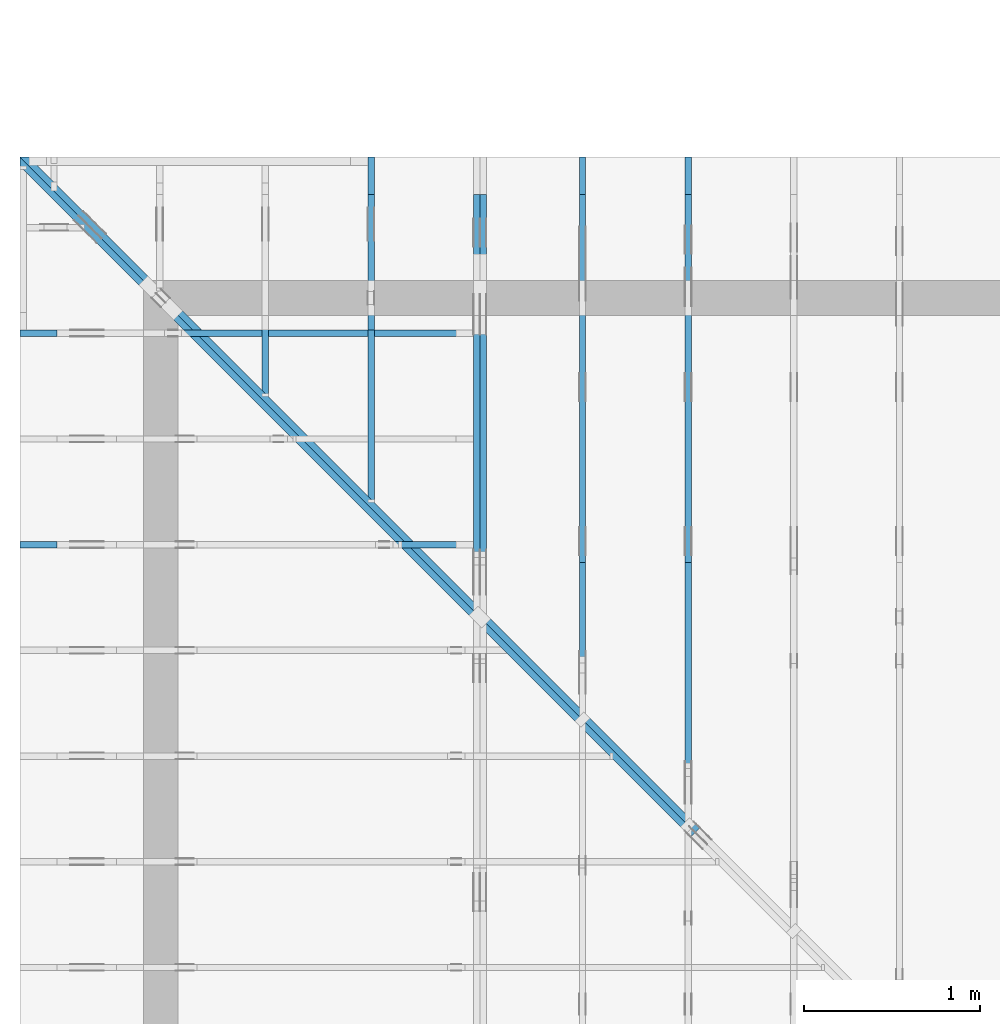
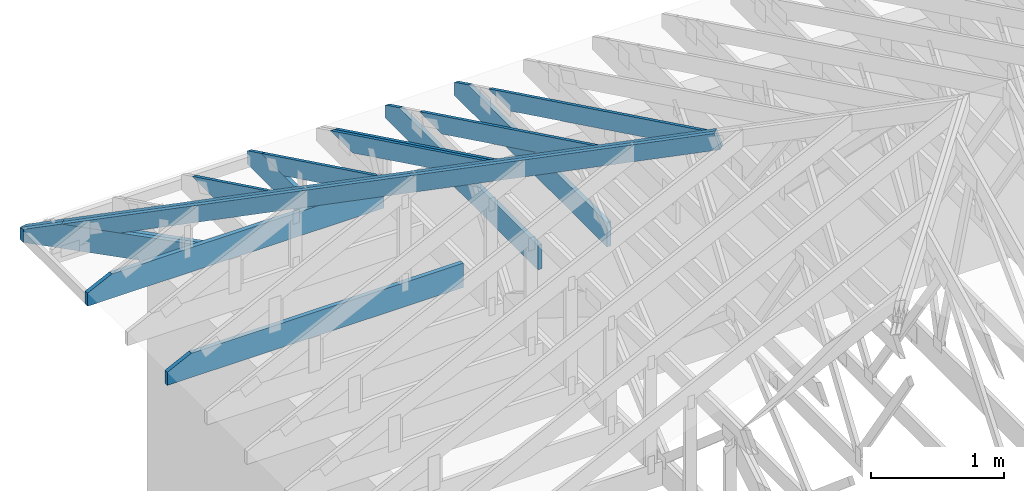
# One storey, part 20 of 159: 15 members, 8 elements without a shape of their own.
"""IFC2X3 building model written with IfcOpenShell, lengths in millimetres."""

from ifc_helpers import new_model, si_unit, frame, origin, origin_with_axes, origin_2d, place, context, project, spatial, faceted_brep, element, aggregate, save


model = new_model("IFC2X3")

# Units and contexts
model_context = context("Model", 3, precision=1e-05, world=origin())
plan_context = context("Plan", 2, precision=1e-05, world=origin_2d())
ifc_project = project(units=[si_unit("LENGTHUNIT", "METRE", prefix="MILLI"), si_unit("AREAUNIT", "SQUARE_METRE"), si_unit("VOLUMEUNIT", "CUBIC_METRE"), si_unit("SOLIDANGLEUNIT", "STERADIAN"), si_unit("PLANEANGLEUNIT", "RADIAN"), si_unit("MASSUNIT", "GRAM"), si_unit("TIMEUNIT", "SECOND"), si_unit("THERMODYNAMICTEMPERATUREUNIT", "DEGREE_CELSIUS"), si_unit("LUMINOUSINTENSITYUNIT", "LUMEN")], contexts=[model_context, plan_context])

# Site, building, storey
site_placement = place(None, origin_with_axes())
site = spatial("IfcSite", under=ifc_project, at=site_placement, CompositionType="ELEMENT")
building_placement = place(site_placement, origin_with_axes())
building = spatial("IfcBuilding", under=site, at=building_placement, Name="Plan 1", CompositionType="ELEMENT")
storey_placement = place(building_placement, origin_with_axes())
storey = spatial("IfcBuildingStorey", under=building, at=storey_placement, Name="Etasje 1", CompositionType="ELEMENT", Elevation=0.0)

# Assembly, member
assembly_1_placement = place(storey_placement, frame((675.0222614047483, 9663.999999999995, 1.1021457184401395e-15), z_axis=(-1.0, 1.836909530733566e-16, 6.123031769111886e-17), x_axis=(-1.836909530733566e-16, -1.0, 0.0)))
assembly_1 = element("IfcElementAssembly", 1, at=assembly_1_placement, inside=storey, Name="S11 (25)", AssemblyPlace="FACTORY", PredefinedType="TRUSS")
member_1_placement = place(assembly_1_placement, frame((240.0601889475118, 89.9784630083152, -36.0000002175812), z_axis=(0.0, 0.0, 1.0), x_axis=(0.898794046299167, 0.4383711467890774, 0.0)))
member_1 = element("IfcMember", 2, at=member_1_placement, Name="S11-O65", context=model_context, shape_type="Brep", body=[
    faceted_brep([(1278.3009822949168, 148.0000008308198, 2.2533470200869488e-06), (1238.2473152975776, 147.9999951378879, 35.99999718738877), (1166.062891346487, 3.2118595072461176e-07, 36.00000021758132), (1206.1165612890213, -1.1368683772161603e-13, 0.0), (6.310887241768095e-30, 148.0000003189115, 2.1758120283266183e-07), (-7.888609052210118e-31, 148.0000003189114, 36.0000002175812), (1238.247314453125, 148.0000003189113, 36.0000002175812), (1278.300983428955, 148.00000031891142, 2.1758120283266183e-07), (303.445009276654, 3.20046368074145e-07, 2.175812028326618e-07), (303.445009276654, 3.20046368074145e-07, 36.0000002175812), (3.7563522717221076e-05, 148.0000018609866, 36.0000002175812), (3.7563522717221076e-05, 148.0000018609866, 2.175812028326618e-07), (1206.1165612036139, 3.212388018164598e-07, 2.175812028326618e-07), (1166.0628922277838, 3.21238699467767e-07, 36.0000002175812), (303.4449913793951, 3.212388579228713e-07, 36.0000002175812), (303.4449913793951, 3.2123896762906077e-07, 2.175812028326618e-07), (1238.2473167004905, 148.00000032118612, 36.0000002175812), (2.5135549549304415e-05, 148.00000032118612, 36.0000002175812), (303.4450324597681, 3.20046467550128e-07, 36.0000002175812), (1166.062891346487, 3.20046467550128e-07, 36.0000002175812), (8.09898806437559e-05, 148.00000032101116, 2.1758120283267173e-07), (1278.3009843101931, 148.00000032101116, 2.1758135937421254e-07), (1206.1165589561892, 3.188434902767767e-07, 2.1758135053446195e-07), (303.44502727894303, 3.188434902767767e-07, 2.1758123999273263e-07)], [[[0, 1, 2, 3]], [[4, 5, 6, 7]], [[8, 9, 10, 11]], [[12, 13, 14, 15]], [[16, 17, 18, 19]], [[20, 21, 22, 23]]]),
])
aggregate(assembly_1, [member_1])

# Assembly, members
assembly_2_placement = place(storey_placement, frame((1275.0222614047495, 9699.999999999993, 1.1021457184401395e-15), z_axis=(-1.0, 1.836909530733566e-16, 6.123031769111886e-17), x_axis=(-1.836909530733566e-16, -1.0, 0.0)))
assembly_2 = element("IfcElementAssembly", 3, at=assembly_2_placement, inside=storey, Name="S12 (24)", AssemblyPlace="FACTORY", PredefinedType="TRUSS")
member_2_placement = place(assembly_2_placement, frame((276.0601952916632, 89.978466102077, -36.000000217584585), z_axis=(0.0, 0.0, 1.0), x_axis=(0.898794046299167, 0.4383711467890774, 0.0)))
member_2 = element("IfcMember", 4, at=member_2_placement, Name="S12-O56", context=model_context, shape_type="Brep", body=[
    faceted_brep([(1945.8621395215064, 148.00000083082477, 2.253349407510541e-06), (1905.8084725241697, 147.99999513788828, 35.999997187395024), (1833.624048573089, 3.2118128956426517e-07, 36.00000021758467), (1873.6777185156202, 1.1368683772161603e-13, 0.0), (0.0, 148.0000003188248, 2.1758457791065666e-07), (0.0, 148.0000003188248, 36.000000217584585), (1905.8084716796877, 148.00000031882468, 36.000000217584585), (1945.8621406555178, 148.00000031882468, 2.1758457791065666e-07), (303.4450022183526, 3.204846024118524e-07, 2.1758457791065666e-07), (303.4450022183526, 3.204846024118524e-07, 36.00000021758458), (3.0505221296550644e-05, 148.00000186142486, 36.00000021758458), (3.0505221296550644e-05, 148.00000186142486, 2.1758457791065666e-07), (1873.6777184301952, 3.2119925995239596e-07, 2.1758457791065666e-07), (1833.6240494543651, 3.21199269514184e-07, 36.00000021758458), (303.44505241457034, 3.2119955059422236e-07, 36.00000021758458), (303.44505241457034, 3.211995483899309e-07, 2.1758457791065666e-07), (1905.8084739270932, 148.00000032118123, 36.00000021758458), (2.5135588998637104e-05, 148.00000032118123, 36.00000021758458), (303.44497142465184, 3.2048473030954483e-07, 36.00000021758458), (1833.6240485730893, 3.2048473030954483e-07, 36.00000021758458), (8.098989928839728e-05, 148.00000031981654, 2.175845779106666e-07), (1945.8621415367745, 148.00000031981654, 2.1758481620217088e-07), (1873.6777161827706, 3.188039272572496e-07, 2.175848073624203e-07), (303.445027278962, 3.188039272572496e-07, 2.175846150707275e-07)], [[[0, 1, 2, 3]], [[4, 5, 6, 7]], [[8, 9, 10, 11]], [[12, 13, 14, 15]], [[16, 17, 18, 19]], [[20, 21, 22, 23]]]),
])
member_3_placement = place(assembly_2_placement, frame((982.00634765625, 223.0, -36.0), z_axis=(0.0, 0.0, 1.0), x_axis=(-1.0, 1.2246063538223773e-16, 0.0)))
member_3 = element("IfcMember", 5, at=member_3_placement, Name="S12-U21", context=model_context, shape_type="Brep", body=[
    faceted_brep([(982.00634765625, 223.00000000001467, 36.0), (0.0, 223.00000000001467, 36.0), (0.0, 0.0, 36.0), (770.8250579833984, 0.0, 36.0), (982.006318893953, 102.99998474121105, 36.0), (0.0, 223.00000000001467, 0.0), (982.00634765625, 223.00000000001467, 1.20257121283375e-13), (982.006318893953, 102.99998474121105, 1.2025711776112584e-13), (770.8250579833984, 0.0, 9.439572636919721e-14), (0.0, 0.0, 0.0), (1.61055054377357e-05, 0.0, 0.0), (1.6105505439939992e-05, -2.6993892992798474e-31, 36.0), (1.6105505467248714e-05, 223.0, 36.0), (1.6105505465044423e-05, 223.0, -1.6721217180559947e-30), (770.8250519745052, -1.4159359023153358e-13, 1.3890631406147823e-29), (770.8250519745052, -1.393892987946533e-13, 36.0), (1.61055054377357e-05, 2.204286696927529e-15, 36.0), (1.61055054377357e-05, -4.739952749857793e-21, 2.9022881271468516e-37), (982.0063188939536, 102.99998597132787, 1.5480697785024754e-29), (982.0063188939536, 102.99998597132787, 36.0), (770.8250519745053, -5.684341886080802e-14, 36.0), (770.8250519745053, -5.684341886080802e-14, 1.1601225646455601e-29), (982.0062942062657, 223.00000000001467, -3.272759518476984e-21), (982.0062942062657, 223.00000000001467, 36.0), (982.0062942062657, 102.9999859713281, 36.0), (982.0062942062657, 102.9999859713281, -1.5116349691744716e-21), (1.61055054377357e-05, 223.0, 0.0), (1.61055054377357e-05, 223.0, 36.0), (982.00634765625, 223.00000000001475, 36.0), (982.00634765625, 223.00000000001478, 6.310887241768095e-30)], [[[0, 1, 2, 3, 4]], [[5, 6, 7, 8, 9]], [[10, 11, 12, 13]], [[14, 15, 16, 17]], [[18, 19, 20, 21]], [[22, 23, 24, 25]], [[26, 27, 28, 29]]]),
])
aggregate(assembly_2, [member_2, member_3])

# Assembly, member
assembly_3_placement = place(storey_placement, frame((-700.000000000007, 8681.993668449246, 1.1021457184401395e-15), z_axis=(0.0, -1.0, 6.123031769111886e-17), x_axis=(1.0, 0.0, 0.0)))
assembly_3 = element("IfcElementAssembly", 6, at=assembly_3_placement, inside=storey, Name="S8 (16)", AssemblyPlace="FACTORY", PredefinedType="TRUSS")
member_4_placement = place(assembly_3_placement, frame((2575.022261404756, 223.00000000093104, -36.0), z_axis=(0.0, 0.0, 1.0), x_axis=(-1.0, 1.2246063538223773e-16, 0.0)))
member_4 = element("IfcMember", 7, at=member_4_placement, Name="S8-U11", context=model_context, shape_type="Brep", body=[
    faceted_brep([(2575.022261404767, 223.00000000093135, 36.0), (4.4607881136471406e-05, 223.00000000093135, 36.0), (4.4607881136471406e-05, 9.310383575211745e-10, 36.0), (2363.8409717319046, 9.310383575211745e-10, 36.0), (2575.0222614047602, 103.00000000093135, 36.0), (4.4607881136471406e-05, 223.00000000093135, 5.462709467027625e-21), (2575.022261404767, 223.00000000093135, 3.1533886225503443e-13), (2575.0222614047602, 103.00000000093135, 3.1533886225503357e-13), (2363.8409717319046, 9.310383575211745e-10, 2.8947746734085526e-13), (4.4607881136471406e-05, 9.310383575211745e-10, 5.462709467027625e-21), (1.1401554882727804e-25, 9.310383575211745e-10, -6.981208276421509e-42), (2.2042914369942947e-15, 9.310383575211745e-10, 36.0), (2.9513013127233304e-14, 223.00000000093104, 36.0), (2.730872169035303e-14, 223.00000000093104, -1.6721217048386645e-30), (2363.8409657211487, 5.200890442812092e-13, -3.184521740901289e-29), (2363.8409657211487, 5.222933357180895e-13, 36.0), (8.67712118026388e-28, 9.310405618126114e-10, 36.0), (0.0, 9.310383575211745e-10, 0.0), (2575.0222614047602, 103.00000000064097, -5.048709793414476e-29), (2575.0222614047602, 103.00000000064097, 36.0), (2363.840965721148, 4.547473508864641e-13, 36.0), (2363.840965721148, 4.547473508864641e-13, -3.7865323450608567e-29), (2575.0222614047543, 223.00000000093135, -7.825500179792437e-28), (2575.0222614047543, 223.00000000093135, 36.0), (2575.0222614047543, 103.00000000064031, 36.0), (2575.0222614047543, 103.00000000064031, -3.534096855390133e-28), (0.0, 223.00000000093104, 0.0), (0.0, 223.00000000093104, 36.0), (2575.022261404767, 223.00000000093144, 36.0), (2575.022261404767, 223.00000000093146, 6.310887241768095e-30)], [[[0, 1, 2, 3, 4]], [[5, 6, 7, 8, 9]], [[10, 11, 12, 13]], [[14, 15, 16, 17]], [[18, 19, 20, 21]], [[22, 23, 24, 25]], [[26, 27, 28, 29]]]),
])
aggregate(assembly_3, [member_4])

assembly_4_placement = place(storey_placement, frame((-700.000000000007, 7481.993668449246, 1.1021457184401395e-15), z_axis=(0.0, -1.0, 6.123031769111886e-17), x_axis=(1.0, 0.0, 0.0)))
assembly_4 = element("IfcElementAssembly", 8, at=assembly_4_placement, inside=storey, Name="S6 (12)", AssemblyPlace="FACTORY", PredefinedType="TRUSS")
member_5_placement = place(assembly_4_placement, frame((2575.022261404756, 223.00000000093104, -36.0), z_axis=(0.0, 0.0, 1.0), x_axis=(-1.0, 1.2246063538223773e-16, 0.0)))
member_5 = element("IfcMember", 9, at=member_5_placement, Name="S6-U11", context=model_context, shape_type="Brep", body=[
    faceted_brep([(2575.022261404767, 223.00000000093135, 36.0), (4.4607881136471406e-05, 223.00000000093135, 36.0), (4.4607881136471406e-05, 9.310383575211745e-10, 36.0), (2363.8409717319046, 9.310383575211745e-10, 36.0), (2575.0222614047602, 103.00000000093135, 36.0), (4.4607881136471406e-05, 223.00000000093135, 5.462709467027625e-21), (2575.022261404767, 223.00000000093135, 3.1533886225503443e-13), (2575.0222614047602, 103.00000000093135, 3.1533886225503357e-13), (2363.8409717319046, 9.310383575211745e-10, 2.8947746734085526e-13), (4.4607881136471406e-05, 9.310383575211745e-10, 5.462709467027625e-21), (1.1401554882727804e-25, 9.310383575211745e-10, -6.981208276421509e-42), (2.2042914369942947e-15, 9.310383575211745e-10, 36.0), (2.9513013127233304e-14, 223.00000000093104, 36.0), (2.730872169035303e-14, 223.00000000093104, -1.6721217048386645e-30), (2363.8409657211487, 5.200890442812092e-13, -3.184521740901289e-29), (2363.8409657211487, 5.222933357180895e-13, 36.0), (8.67712118026388e-28, 9.310405618126114e-10, 36.0), (0.0, 9.310383575211745e-10, 0.0), (2575.0222614047602, 103.00000000064097, -5.048709793414476e-29), (2575.0222614047602, 103.00000000064097, 36.0), (2363.840965721148, 4.547473508864641e-13, 36.0), (2363.840965721148, 4.547473508864641e-13, -3.7865323450608567e-29), (2575.0222614047543, 223.00000000093135, -7.825500179792437e-28), (2575.0222614047543, 223.00000000093135, 36.0), (2575.0222614047543, 103.00000000064031, 36.0), (2575.0222614047543, 103.00000000064031, -3.534096855390133e-28), (0.0, 223.00000000093104, 0.0), (0.0, 223.00000000093104, 36.0), (2575.022261404767, 223.00000000093144, 36.0), (2575.022261404767, 223.00000000093146, 6.310887241768095e-30)], [[[0, 1, 2, 3, 4]], [[5, 6, 7, 8, 9]], [[10, 11, 12, 13]], [[14, 15, 16, 17]], [[18, 19, 20, 21]], [[22, 23, 24, 25]], [[26, 27, 28, 29]]]),
])
aggregate(assembly_4, [member_5])

# Assembly, members
assembly_5_placement = place(storey_placement, frame((-725.455844122723, 9674.544155877278, 2.204291436880279e-15), z_axis=(-0.7071067811865477, -0.7071067811865474, 6.123031769111886e-17), x_axis=(0.7071067811865474, -0.7071067811865477, 0.0)))
assembly_5 = element("IfcElementAssembly", 10, at=assembly_5_placement, inside=storey, Name="GR1 (7)", AssemblyPlace="FACTORY", PredefinedType="TRUSS")
member_6_placement = place(assembly_5_placement, frame((382.90850618663825, 83.08701368323861, -36.00000195234117), z_axis=(0.0, 0.0, 1.0), x_axis=(0.9453579955214152, 0.32603413978252627, 0.0)))
member_6 = element("IfcMember", 11, at=member_6_placement, Name="GR1-O2", context=model_context, shape_type="Brep", body=[
    faceted_brep([(9.094947017729282e-13, 148.00000315181347, 1.952341179389805e-06), (9.094947017729282e-13, 148.00000315181347, 36.00000195234118), (5380.000000000001, 148.00000315181313, 36.00000195234118), (5380.000000000001, 148.00000315181313, 1.952341179389805e-06), (429.13598996492084, 3.151003625134763e-06, 1.952341179389805e-06), (429.13598996492084, 3.151003625134763e-06, 36.00000195234118), (6.069707794154056e-06, 148.00000105849915, 36.00000195234118), (6.069707794154056e-06, 148.00000105849915, 1.952341179389805e-06), (5379.999999999999, 3.1509182713895772e-06, 1.952341179389805e-06), (5379.999999999999, 3.1509182735938687e-06, 36.00000195234118), (429.1362304687506, 3.150919183022753e-06, 36.00000195234118), (429.1362304687506, 3.1509191808184616e-06, 1.952341179389805e-06), (5380.0, 148.00000277524896, 1.8783536717137395e-06), (5379.999999999999, 148.00000277524896, 36.00000195234118), (5379.999999999999, 0.0, 36.00000255341424), (5380.0, 0.0, 0.0), (5379.999999999999, 148.00000315091938, 36.00000195234118), (4.547473508864641e-13, 148.00000315091938, 36.00000195234118), (429.1362304687506, 3.151003227230831e-06, 36.00000195234118), (5379.999999999999, 3.151003227230831e-06, 36.00000195234118), (0.0, 148.0000031518136, 1.952341179389805e-06), (5379.999999999999, 148.0000031518136, 1.9523418382280232e-06), (5380.0, 3.150919837935362e-06, 1.9523418382280232e-06), (429.1362304687497, 3.150919837935362e-06, 1.9523412319421e-06)], [[[0, 1, 2, 3]], [[4, 5, 6, 7]], [[8, 9, 10, 11]], [[12, 13, 14, 15]], [[16, 17, 18, 19]], [[20, 21, 22, 23]]]),
])
member_7_placement = place(assembly_5_placement, frame((382.90850618663825, 83.08701368323861, -72.00000195234118), z_axis=(0.0, 0.0, 1.0), x_axis=(0.9453579955214152, 0.32603413978252627, 0.0)))
member_7 = element("IfcMember", 12, at=member_7_placement, Name="GR1-O2", context=model_context, shape_type="Brep", body=[
    faceted_brep([(9.094947017729282e-13, 148.00000315181347, 1.952341179389805e-06), (9.094947017729282e-13, 148.00000315181347, 36.00000195234118), (5380.000000000001, 148.00000315181313, 36.00000195234118), (5380.000000000001, 148.00000315181313, 1.952341179389805e-06), (429.13598996492084, 3.151003625134763e-06, 1.952341179389805e-06), (429.13598996492084, 3.151003625134763e-06, 36.00000195234118), (6.069707794154056e-06, 148.00000105849915, 36.00000195234118), (6.069707794154056e-06, 148.00000105849915, 1.952341179389805e-06), (5379.999999999999, 3.1509182713895772e-06, 1.952341179389805e-06), (5379.999999999999, 3.1509182735938687e-06, 36.00000195234118), (429.1362304687506, 3.150919183022753e-06, 36.00000195234118), (429.1362304687506, 3.1509191808184616e-06, 1.952341179389805e-06), (5380.0, 148.00000277524896, 1.8783536717137395e-06), (5379.999999999999, 148.00000277524896, 36.00000195234118), (5379.999999999999, 0.0, 36.00000255341424), (5380.0, 0.0, 0.0), (5379.999999999999, 148.00000315091938, 36.00000195234118), (4.547473508864641e-13, 148.00000315091938, 36.00000195234118), (429.1362304687506, 3.151003227230831e-06, 36.00000195234118), (5379.999999999999, 3.151003227230831e-06, 36.00000195234118), (0.0, 148.0000031518136, 1.952341179389805e-06), (5379.999999999999, 148.0000031518136, 1.9523418382280232e-06), (5380.0, 3.150919837935362e-06, 1.9523418382280232e-06), (429.1362304687497, 3.150919837935362e-06, 1.9523412319421e-06)], [[[0, 1, 2, 3]], [[4, 5, 6, 7]], [[8, 9, 10, 11]], [[12, 13, 14, 15]], [[16, 17, 18, 19]], [[20, 21, 22, 23]]]),
])
member_8_placement = place(assembly_5_placement, frame((1388.7666724168134, 223.00000146033642, -36.000001069758746), z_axis=(0.0, 0.0, 1.0), x_axis=(-1.0, -3.216285744678249e-16, 0.0)))
member_8 = element("IfcMember", 13, at=member_8_placement, Name="GR1-U18.1", context=model_context, shape_type="Brep", body=[
    faceted_brep([(4.638422979073698e-11, 1.460336420677777e-06, 1.0697587455865687e-06), (36.00000106978201, 1.460336448243618e-06, 36.00000213954348), (36.000001069782, 223.00000146033645, 36.000002139543646), (4.618516542006392e-11, 223.00000146033642, 1.069758717277264e-06), (4.615685611497611e-11, 223.00000146033605, 1.0697587455865687e-06), (36.00000000004616, 223.00000146033605, 36.000001069758746), (1352.7667236328587, 223.00000146033597, 36.000001069758746), (1388.7667236328587, 223.00000146033597, 1.0697587455865687e-06), (1352.7667236328123, 223.00000146032178, 36.000001069758746), (35.99999999999977, 223.00000146032178, 36.000001069758746), (36.0, 1.4603356532916223e-06, 36.000001069758746), (1054.1112060546873, 1.4603356532916223e-06, 36.000001069758746), (1352.7667236328123, 103.00000146033567, 36.000001069758746), (1388.7666734865709, 223.00000146010453, -1.3642420526593924e-12), (1352.7666724168116, 223.00000146010453, 36.00000106975813), (1352.7666724168116, 103.00000146010454, 36.00000106975813), (1388.765985650004, 115.41540864089114, 0.0006878365655893504), (1054.1112060546875, 1.4603362270470847e-06, 1.0697587455865687e-06), (1054.1112060546875, 1.460336197276953e-06, 36.000001069758746), (36.0, 1.460336384294771e-06, 36.000001069758746), (-2.350988701644575e-38, 1.460336420677777e-06, 1.0697587455865687e-06), (1388.765984321453, 115.4154088985598, 0.0006891651179756764), (1352.766670783397, 103.000000896774, 36.00000251961016), (1054.111215709375, -1.7053025658242404e-13, 36.000002519610156), (1054.111215709375, -1.7053025658242404e-13, 1.0697737380382932e-06), (4.615685611497611e-11, 223.00000146033642, 1.0697587455865687e-06), (1388.7667236328589, 223.00000146033642, 1.069758915655824e-06), (1388.7659912109839, 115.4154067337739, 1.0697589156557344e-06), (1054.1112060547339, 1.4603360796172637e-06, 1.0697588746736968e-06), (4.638422979041934e-11, 1.4603360796172637e-06, 1.0697587455865687e-06)], [[[0, 1, 2, 3]], [[4, 5, 6, 7]], [[8, 9, 10, 11, 12]], [[13, 14, 15, 16]], [[17, 18, 19, 20]], [[21, 22, 23, 24]], [[25, 26, 27, 28, 29]]]),
])
member_9_placement = place(assembly_5_placement, frame((1424.766723632812, 223.00000338444437, -72.00000132855342), z_axis=(0.0, 0.0, 1.0), x_axis=(-1.0, -3.216285744678249e-16, 0.0)))
member_9 = element("IfcMember", 14, at=member_9_placement, Name="GR1-U18.1", context=model_context, shape_type="Brep", body=[
    faceted_brep([(5.014701721921023e-05, 3.38444403610405e-06, 2.5806090815883666e-07), (36.000051216044774, 3.384443999721043e-06, 36.00000132855365), (36.000051216044774, 223.000003384444, 36.000001328553424), (5.0147017189787936e-05, 223.00000338444403, 2.580606533640315e-07), (1090.1112572707325, 3.38444416895969e-06, 1.3285534237184038e-06), (1090.1112572707325, 3.3844441711639813e-06, 36.000001328553424), (36.000051216044994, 3.3844443647946733e-06, 36.000001328553424), (5.1216044994362164e-05, 3.384444369203256e-06, 1.3285534237184038e-06), (1388.7667223042588, 223.00000554923048, 0.0), (1424.766723632827, 223.00000554923048, 36.00000132856803), (1424.7660355374514, 115.41541082266798, 35.999313233192424), (1388.7667223042588, 103.00000364188185, 0.0), (5.1217499049016624e-05, 223.00000338444437, 1.3285534237184038e-06), (36.00005121749905, 223.00000338444437, 36.000001328553424), (1424.7667748503115, 223.00000338444428, 36.000001328553424), (1388.7667748503115, 223.00000338444428, 1.3285534237184038e-06), (0.0, 223.00000338444437, 1.3285534237184038e-06), (1388.7667236328125, 223.00000338444437, 1.328553593787659e-06), (1388.7667236328125, 103.00000338442975, 1.328553593787659e-06), (1090.1112670898438, 3.3844297604446183e-06, 1.3285535572141222e-06), (0.0, 3.3844297604446183e-06, 1.3285534237184038e-06), (1424.7660371708682, 115.4154113859991, 35.99931468304562), (1090.1112613462794, 5.115907697472721e-13, 36.000001328553395), (1090.1112613462794, 5.115907697472721e-13, 1.3285534237184036e-06), (1388.7667236328123, 103.00000338421381, 1.3285534237184036e-06), (1424.7667748488573, 223.00000338442936, 36.000001328553424), (36.00005121604477, 223.00000338442936, 36.000001328553424), (36.000051216044994, 3.384443999721043e-06, 36.000001328553424), (1090.1112572707323, 3.384443999721043e-06, 36.000001328553424), (1424.7660424269823, 115.41540865788149, 36.000001328553424)], [[[0, 1, 2, 3]], [[4, 5, 6, 7]], [[8, 9, 10, 11]], [[12, 13, 14, 15]], [[16, 17, 18, 19, 20]], [[21, 22, 23, 24]], [[25, 26, 27, 28, 29]]]),
])
aggregate(assembly_5, [member_6, member_7, member_8, member_9])

assembly_6_placement = place(storey_placement, frame((3075.02226140475, 9699.999999999993, 1.1021457184401395e-15), z_axis=(-1.0, 1.836909530733566e-16, 6.123031769111886e-17), x_axis=(-1.836909530733566e-16, -1.0, 0.0)))
assembly_6 = element("IfcElementAssembly", 15, at=assembly_6_placement, inside=storey, Name="V3 (4)", AssemblyPlace="FACTORY", PredefinedType="TRUSS")
member_10_placement = place(assembly_6_placement, frame((579.5051537710235, 237.97846118691618, -36.000000217582375), z_axis=(0.0, 0.0, 1.0), x_axis=(0.8987940462991671, 0.4383711467890776, 0.0)))
member_10 = element("IfcMember", 16, at=member_10_placement, Name="V3-O28/", context=model_context, shape_type="Brep", body=[
    faceted_brep([(3610.932182745316, 148.00000083081443, 2.2533320134243695e-06), (3570.878515747978, 147.99999513788862, 35.99999718737445), (3498.694091796876, 3.211916919099167e-07, 36.00000021758342), (3538.7477617394097, -4.547473508864641e-13, 1.1368683772161603e-12), (9.693632694052212e-05, 148.00000032212483, 2.1758236812274845e-07), (9.693632694052212e-05, 148.00000032212506, 36.00000021758236), (3570.8785149050773, 148.00000032212483, 36.00000021758236), (3610.9321838809074, 148.0000003221246, 2.1758236812274845e-07), (303.4450134257046, 3.229121858794315e-07, 2.1758236812274845e-07), (303.4450134257046, 3.229121858794315e-07, 36.00000021758237), (4.1712573199959024e-05, 148.0000018638525, 36.00000021758237), (4.1712573199959024e-05, 148.0000018638525, 2.1758236812274845e-07), (3538.74776165397, 3.2117012349582686e-07, 2.1758236812274842e-07), (3498.69409267814, 3.211703568785767e-07, 36.00000021758237), (303.44502727896975, 3.211709438169228e-07, 36.00000021758237), (303.44502727896975, 3.211707177916696e-07, 2.1758236812274842e-07), (3570.878517150879, 148.00000032119237, 36.00000021758237), (0.0, 148.00000032119237, 36.00000021758237), (303.4450683593749, 3.229122853554145e-07, 36.00000021758237), (3498.694091796875, 3.229122853554145e-07, 36.00000021758237), (5.5855932146187115e-05, 148.00000032224412, 2.1758236812275528e-07), (3610.9321847621823, 148.00000032224412, 2.175828103197981e-07), (3538.7477594081784, 3.2212346923188306e-07, 2.1758280148004752e-07), (303.4451242153068, 3.2212346923188306e-07, 2.1758240528283117e-07)], [[[0, 1, 2, 3]], [[4, 5, 6, 7]], [[8, 9, 10, 11]], [[12, 13, 14, 15]], [[16, 17, 18, 19]], [[20, 21, 22, 23]]]),
])
member_11_placement = place(assembly_6_placement, frame((2300.0, 223.0, -36.0), z_axis=(0.0, 0.0, 1.0), x_axis=(-1.0, 1.2246063538223773e-16, 0.0)))
member_11 = element("IfcMember", 17, at=member_11_placement, Name="V3-U14", context=model_context, shape_type="Brep", body=[
    faceted_brep([(2300.000000000021, 223.0, 36.0), (0.0, 223.0, 36.0), (0.0, 0.0, 36.0), (2088.8187103271484, 0.0, 36.0), (2300.0000000000095, 103.00000000000028, 36.0), (0.0, 223.0, 0.0), (2300.000000000021, 223.0, 2.8165946137914934e-13), (2300.0000000000095, 103.00000000000028, 2.8165946137914793e-13), (2088.8187103271484, 2.5579538487363607e-13, 2.5579806646496897e-13), (0.0, 2.5579538487363607e-13, 0.0), (2088.818704317331, -3.836970985935046e-13, 3.91563279237756e-29), (2088.818704317331, -3.814928071566243e-13, 36.0), (1.8189894035458565e-12, 2.204291436879722e-15, 36.0), (1.8189894035458565e-12, -5.568841607314696e-28, 3.4098194078739984e-44), (2300.0000000000095, 103.00000000000114, -3.155443620884047e-29), (2300.0000000000095, 103.00000000000114, 36.0), (2088.8187043173316, 7.958078640513122e-13, 36.0), (2088.8187043173316, 7.958078640513122e-13, -3.155443620884047e-29), (2300.0, 223.00000000000028, -1.2874209973206913e-27), (2300.0, 223.00000000000028, 36.0), (2300.0, 103.0000000000006, 36.0), (2300.0, 103.0000000000006, -5.806016262426647e-28), (2.2737367544323206e-11, 223.0, 0.0), (2.2737367544323206e-11, 223.0, 36.0), (2300.000000000021, 223.00000000000037, 36.0), (2300.000000000021, 223.00000000000037, 4.733165431326071e-30), (1.8189894035458565e-12, 0.0, 0.0), (1.8211936949827368e-12, -2.068182698939301e-28, 36.0), (2.2744232007747972e-11, 223.0, 36.0), (2.2742027716311092e-11, 223.0, -2.8534381131350165e-31)], [[[0, 1, 2, 3, 4]], [[5, 6, 7, 8, 9]], [[10, 11, 12, 13]], [[14, 15, 16, 17]], [[18, 19, 20, 21]], [[22, 23, 24, 25]], [[26, 27, 28, 29]]]),
])
aggregate(assembly_6, [member_10, member_11])

assembly_7_placement = place(storey_placement, frame((2475.02226140475, 9699.999999999993, 1.1021457184401395e-15), z_axis=(-1.0, 1.836909530733566e-16, 6.123031769111886e-17), x_axis=(-1.836909530733566e-16, -1.0, 0.0)))
assembly_7 = element("IfcElementAssembly", 18, at=assembly_7_placement, inside=storey, Name="V2 (3)", AssemblyPlace="FACTORY", PredefinedType="TRUSS")
member_12_placement = place(assembly_7_placement, frame((579.5050879137441, 237.9784290667213, -36.000000217603684), z_axis=(0.0, 0.0, 1.0), x_axis=(0.898794046299167, 0.4383711467890774, 0.0)))
member_12 = element("IfcMember", 19, at=member_12_placement, Name="V2-O39", context=model_context, shape_type="Brep", body=[
    faceted_brep([(2943.3710917330595, 148.00000083083978, 2.25330154535186e-06), (2903.3174247357406, 147.99999513789794, 35.99999718736581), (2831.1330007846914, 3.2117611681314884e-07, 36.000000217603656), (2871.186670727205, -1.1368683772161603e-13, 0.0), (4.10803902468615e-05, 148.00000032210428, 2.176036772993939e-07), (4.10803902468615e-05, 148.00000032210428, 36.00000021760368), (2903.3174238928905, 148.0000003221041, 36.00000021760368), (2943.3710928687206, 148.0000003221041, 2.176036772993939e-07), (303.4450866984018, 3.224205755714138e-07, 2.176036772993939e-07), (303.4450866984018, 3.224205755714138e-07, 36.00000021760368), (0.00011498527047137941, 148.00000186336086, 36.00000021760368), (0.00011498527047137941, 148.00000186336084, 2.176036772993939e-07), (2871.1866706417886, 3.211556306445953e-07, 2.176036772993939e-07), (2831.1330016659585, 3.211558720209509e-07, 36.00000021760368), (303.44497142303806, 3.2115633633437425e-07, 36.00000021760368), (303.44497142303806, 3.2115610231551527e-07, 2.176036772993939e-07), (2903.317426138695, 148.00000032117623, 36.00000021760368), (0.0001882846904663893, 148.00000032117623, 36.00000021760368), (303.44501250344035, 3.224207603125251e-07, 36.00000021760368), (2831.133000784691, 3.224207603125251e-07, 36.00000021760368), (0.0, 148.00000032175237, 2.176036772993939e-07), (2943.371093750001, 148.00000032175237, 2.176040377464882e-07), (2871.186668395996, 3.2210914469033014e-07, 2.1760402890673762e-07), (303.44506835937534, 3.2210914469033014e-07, 2.1760371445946978e-07)], [[[0, 1, 2, 3]], [[4, 5, 6, 7]], [[8, 9, 10, 11]], [[12, 13, 14, 15]], [[16, 17, 18, 19]], [[20, 21, 22, 23]]]),
])
member_13_placement = place(assembly_7_placement, frame((2300.0, 223.0, -36.0), z_axis=(0.0, 0.0, 1.0), x_axis=(-1.0, 1.2246063538223773e-16, 0.0)))
member_13 = element("IfcMember", 20, at=member_13_placement, Name="V2-U14", context=model_context, shape_type="Brep", body=[
    faceted_brep([(2300.0, 223.0, 36.0), (0.0, 223.0, 36.0), (0.0, 0.0, 36.0), (2088.8187103271484, 0.0, 36.0), (2300.0, 103.00000000000028, 36.0), (0.0, 223.0, 0.0), (2300.0, 223.0, 2.8165946137914677e-13), (2300.0, 103.00000000000028, 2.8165946137914677e-13), (2088.8187103271484, 2.5579538487363607e-13, 2.5579806646496897e-13), (0.0, 2.5579538487363607e-13, 0.0), (2088.818704317331, -3.836970985935046e-13, 3.91563279237756e-29), (2088.818704317331, -3.814928071566243e-13, 36.0), (1.8189894035458565e-12, 2.204291436879722e-15, 36.0), (1.8189894035458565e-12, -5.568841607314696e-28, 3.4098194078739984e-44), (2299.9999999999995, 103.00000000000091, -3.155443620884047e-29), (2299.9999999999995, 103.00000000000091, 36.0), (2088.8187043173307, 5.684341886080801e-13, 36.0), (2088.8187043173307, 5.684341886080801e-13, -3.155443620884047e-29), (2300.0, 223.00000000000028, 0.0), (2300.0, 223.00000000000028, 36.0), (2300.0, 103.00000000000063, 36.0), (2300.0, 103.00000000000063, 0.0), (1.8189894035458565e-12, 223.0, 0.0), (1.8189894035458565e-12, 223.0, 36.0), (2300.0, 223.00000000000037, 36.0), (2300.0, 223.00000000000037, 4.733165431326071e-30), (1.8189894035458565e-12, 0.0, 0.0), (1.8211936949827368e-12, -2.6993892992798474e-31, 36.0), (1.8485024166729758e-12, 223.0, 36.0), (1.8462981252360955e-12, 223.0, -1.6721217048316832e-30)], [[[0, 1, 2, 3, 4]], [[5, 6, 7, 8, 9]], [[10, 11, 12, 13]], [[14, 15, 16, 17]], [[18, 19, 20, 21]], [[22, 23, 24, 25]], [[26, 27, 28, 29]]]),
])
aggregate(assembly_7, [member_12, member_13])

assembly_8_placement = place(storey_placement, frame((1875.0222614047502, 9699.999999999993, 0.0), z_axis=(-1.0, 1.836909530733566e-16, 6.123031769111886e-17), x_axis=(-1.836909530733566e-16, -1.0, 0.0)))
assembly_8 = element("IfcElementAssembly", 21, at=assembly_8_placement, inside=storey, Name="V1 (2)", AssemblyPlace="FACTORY", PredefinedType="TRUSS")
member_14_placement = place(assembly_8_placement, frame((276.0601647137416, 89.97845118796718, -36.00000021760371), z_axis=(0.0, 0.0, 1.0), x_axis=(0.898794046299167, 0.4383711467890774, 0.0)))
member_14 = element("IfcMember", 22, at=member_14_placement, Name="V1-O43.1/", context=model_context, shape_type="Brep", body=[
    faceted_brep([(2613.4233378276135, 148.00000083083967, 2.253302000099211e-06), (2573.3696708302946, 147.99999513789783, 35.99999718736626), (2501.185246879245, 3.2117640103024314e-07, 36.00000021760388), (2541.2389168217587, 0.0, 0.0), (4.108040212713604e-05, 148.00000032047933, 2.1760371282653068e-07), (4.108040212713604e-05, 148.00000032047933, 36.00000021760371), (2573.3696699866523, 148.00000032047973, 36.00000021760371), (2613.4233389624824, 148.00000032047976, 2.1760371282653068e-07), (0.0, 148.00000032168498, 2.1760371282653068e-07), (2613.4233398437495, 148.00000032168498, 2.176040328680134e-07), (2541.238914489746, 3.2046045816969126e-07, 2.1760402402826282e-07), (303.4450683593748, 3.2046045816969126e-07, 2.1760374998660654e-07), (303.4450362378482, 3.215365325104358e-07, 2.1760371282653068e-07), (303.4450362378482, 3.215365325104358e-07, 36.00000021760371), (6.452471689755157e-05, 148.0000018624768, 36.00000021760371), (6.452471689755157e-05, 148.0000018624768, 2.1760371282653068e-07), (2541.238916736348, 3.211695263372542e-07, 2.176037128265307e-07), (2501.185247760518, 3.2116953589904227e-07, 36.00000021760371), (303.4449714238483, 3.2116993960404826e-07, 36.00000021760371), (303.4449714238483, 3.211699373997568e-07, 2.176037128265307e-07), (2573.3696722332484, 148.00000032117646, 36.00000021760371), (0.00018828549440286224, 148.00000032117646, 36.00000021760371), (303.44501250424446, 3.215367314624018e-07, 36.00000021760371), (2501.185246879245, 3.215367314624018e-07, 36.00000021760371)], [[[0, 1, 2, 3]], [[4, 5, 6, 7]], [[8, 9, 10, 11]], [[12, 13, 14, 15]], [[16, 17, 18, 19]], [[20, 21, 22, 23]]]),
])
member_15_placement = place(assembly_8_placement, frame((276.06012779092157, 89.97843317950081, -72.00000021759465), z_axis=(0.0, 0.0, 1.0), x_axis=(0.898794046299167, 0.4383711467890774, 0.0)))
member_15 = element("IfcMember", 23, at=member_15_placement, Name="V1-O43.1/", context=model_context, shape_type="Brep", body=[
    faceted_brep([(2653.4770487651294, 148.00000083083904, 2.2533299670612905e-06), (2613.4233817678014, 147.9999951378946, 35.99999718738559), (2541.2389578167513, 3.211731609553681e-07, 36.00000021759524), (2581.2926277592733, -3.410605131648481e-13, 6.821210263296962e-13), (4.108040275241365e-05, 148.0000003204643, 2.1759464630122238e-07), (4.108040275241365e-05, 148.00000032046407, 36.00000021759464), (2613.4233809241523, 148.0000003204639, 36.00000021759464), (2653.477049899983, 148.00000032046412, 2.1759464630122238e-07), (303.4450773182511, 3.2153994311556744e-07, 2.1759464630122238e-07), (303.4450773182511, 3.2153994311556744e-07, 36.000000217594646), (0.00010560511977075748, 148.00000186248022, 36.000000217594646), (0.00010560511977075748, 148.00000186248022, 2.1759464630122238e-07), (2581.292627673854, 3.2116627297955987e-07, 2.1759464630122238e-07), (2541.238958698024, 3.2116628254134794e-07, 36.000000217594646), (303.4449714238542, 3.2116669360385824e-07, 36.000000217594646), (303.4449714238542, 3.211666913995668e-07, 2.1759464630122238e-07), (2613.423383170755, 148.0000003211735, 36.000000217594646), (0.00018828550099669883, 148.0000003211735, 36.000000217594646), (303.44501250425117, 3.215401989109523e-07, 36.000000217594646), (2541.238957816751, 3.215401989109523e-07, 36.000000217594646), (0.0, 148.00000032168822, 2.1759464630122238e-07), (2653.4770507812495, 148.00000032168822, 2.17594971247708e-07), (2581.292625427246, 3.20445451507112e-07, 2.175949624079574e-07), (303.4450683593749, 3.20445451507112e-07, 2.1759468346129824e-07)], [[[0, 1, 2, 3]], [[4, 5, 6, 7]], [[8, 9, 10, 11]], [[12, 13, 14, 15]], [[16, 17, 18, 19]], [[20, 21, 22, 23]]]),
])
aggregate(assembly_8, [member_14, member_15])

save(model, "model.ifc")
